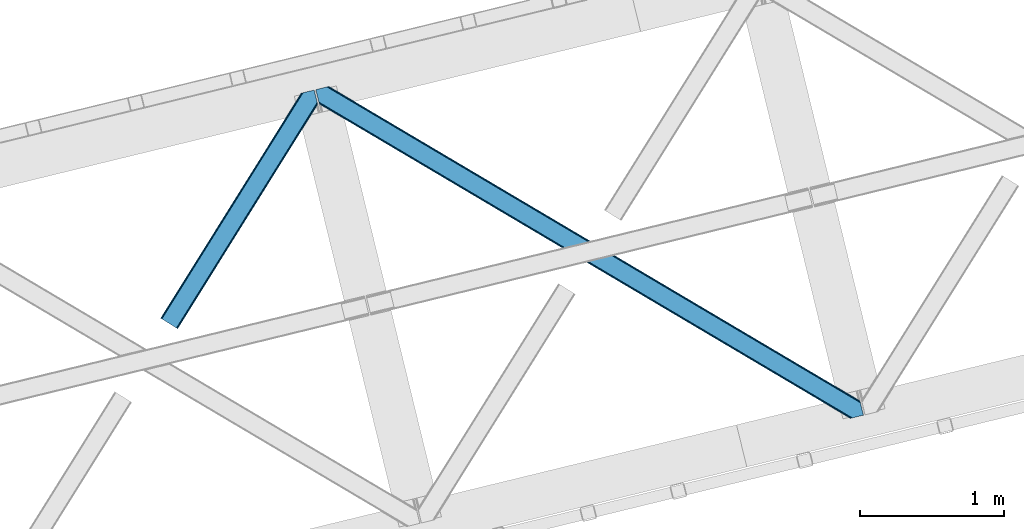
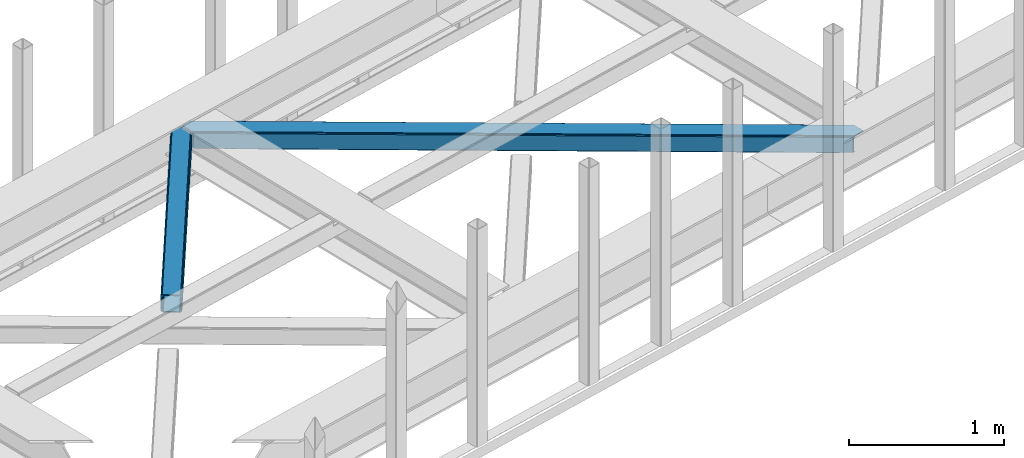
# One storey, part 43 of 66: 2 members.
"""IFC4 building model written with IfcOpenShell, lengths in millimetres."""

from ifc_helpers import new_model, entity, si_unit, converted_unit, derived_unit, direction, frame, origin, place, context, subcontext, project, spatial, triangles, type_object, element, save


model = new_model("IFC4")

# Units and contexts
model_context = context("Model", 3, precision=0.01, world=origin(), true_north=direction((6.12303176911189e-17, 1.0)))
plan_context = context("Plan", 3, precision=0.01, world=origin(), true_north=direction((6.12303176911189e-17, 1.0)))
body_context = subcontext(model_context, "Body", "Model", "MODEL_VIEW")
ifc_project = project(units=[si_unit("LENGTHUNIT", "METRE", prefix="MILLI"), si_unit("AREAUNIT", "SQUARE_METRE"), si_unit("VOLUMEUNIT", "CUBIC_METRE"), converted_unit("PLANEANGLEUNIT", "DEGREE", entity("IfcRatioMeasure", 0.0174532925199433), si_unit("PLANEANGLEUNIT", "RADIAN"), dimensions=[0, 0, 0, 0, 0, 0, 0]), si_unit("MASSUNIT", "GRAM", prefix="KILO"), derived_unit("MASSDENSITYUNIT", [(si_unit("MASSUNIT", "GRAM", prefix="KILO"), 1), (si_unit("LENGTHUNIT", "METRE"), -3)]), derived_unit("MOMENTOFINERTIAUNIT", [(si_unit("LENGTHUNIT", "METRE"), 4)]), si_unit("TIMEUNIT", "SECOND"), si_unit("FREQUENCYUNIT", "HERTZ"), si_unit("THERMODYNAMICTEMPERATUREUNIT", "DEGREE_CELSIUS"), derived_unit("THERMALTRANSMITTANCEUNIT", [(si_unit("MASSUNIT", "GRAM", prefix="KILO"), 1), (si_unit("THERMODYNAMICTEMPERATUREUNIT", "KELVIN"), -1), (si_unit("TIMEUNIT", "SECOND"), -3)]), derived_unit("VOLUMETRICFLOWRATEUNIT", [(si_unit("LENGTHUNIT", "METRE"), 3), (si_unit("TIMEUNIT", "SECOND"), -1)]), derived_unit("MASSFLOWRATEUNIT", [(si_unit("MASSUNIT", "GRAM", prefix="KILO"), 1), (si_unit("TIMEUNIT", "SECOND"), -1)]), derived_unit("ROTATIONALFREQUENCYUNIT", [(si_unit("TIMEUNIT", "SECOND"), -1)]), si_unit("ELECTRICCURRENTUNIT", "AMPERE"), si_unit("ELECTRICVOLTAGEUNIT", "VOLT"), si_unit("POWERUNIT", "WATT"), si_unit("FORCEUNIT", "NEWTON", prefix="KILO"), si_unit("ILLUMINANCEUNIT", "LUX"), si_unit("LUMINOUSFLUXUNIT", "LUMEN"), si_unit("LUMINOUSINTENSITYUNIT", "CANDELA"), derived_unit("USERDEFINED", [(si_unit("MASSUNIT", "GRAM", prefix="KILO"), -1), (si_unit("LENGTHUNIT", "METRE"), -2), (si_unit("TIMEUNIT", "SECOND"), 3), (si_unit("LUMINOUSFLUXUNIT", "LUMEN"), 1)]), derived_unit("LINEARVELOCITYUNIT", [(si_unit("LENGTHUNIT", "METRE"), 1), (si_unit("TIMEUNIT", "SECOND"), -1)]), si_unit("PRESSUREUNIT", "PASCAL"), derived_unit("USERDEFINED", [(si_unit("LENGTHUNIT", "METRE"), -2), (si_unit("MASSUNIT", "GRAM", prefix="KILO"), 1), (si_unit("TIMEUNIT", "SECOND"), -2)]), derived_unit("LINEARFORCEUNIT", [(si_unit("MASSUNIT", "GRAM", prefix="KILO"), 1), (si_unit("LENGTHUNIT", "METRE"), 1), (si_unit("TIMEUNIT", "SECOND"), -2), (si_unit("LENGTHUNIT", "METRE"), -1)]), derived_unit("PLANARFORCEUNIT", [(si_unit("MASSUNIT", "GRAM", prefix="KILO"), 1), (si_unit("LENGTHUNIT", "METRE"), 1), (si_unit("TIMEUNIT", "SECOND"), -2), (si_unit("LENGTHUNIT", "METRE"), -2)])], contexts=[model_context, plan_context])

# Site, building, storey
site_placement = place(None, origin())
site = spatial("IfcSite", under=ifc_project, at=site_placement, CompositionType="ELEMENT")
building_placement = place(site_placement, origin())
building = spatial("IfcBuilding", under=site, at=building_placement, CompositionType="ELEMENT")
storey_placement = place(building_placement, frame((0.0, 0.0, 19800.0)))
storey = spatial("IfcBuildingStorey", under=building, at=storey_placement, Name="06", CompositionType="ELEMENT", Elevation=19800.0)

# Members
member_type_1 = type_object("IfcMemberType", PredefinedType="BRACE")
member_1_placement = place(storey_placement, frame((-25090.06, 13275.86, 3823.0)))
element("IfcMember", 1, at=member_1_placement, inside=storey, type_object=member_type_1, ObjectType="Steel Horizontal Brace", PredefinedType="BRACE", context=body_context, shape_type="Tessellation", body=[
    triangles([(933.019793701173, 1535.69230957031, 0.0), (967.780462646486, 1393.09171142578, 0.0), (14.8456054687485, 64.8704589843746, 0.0), (103.916912841796, 9.2680389404286, 0.0), (928.803771972656, 1552.99125366211, 5.49966430664063), (928.943298339844, 1552.41687011719, 5.208984375), (930.803649902344, 1544.78710327148, 1.33247680664135), (971.996484374999, 1375.79276733398, 5.49966430664063), (971.856958007811, 1376.36715087891, 5.208984375), (969.996606445311, 1383.99691772461, 1.33247680664135), (972.210424804689, 1375.53813171387, 5.8531311035149), (972.422039794921, 1375.28349609375, 6.20659790039281), (928.913067626952, 1553.56912536621, 5.74383544921875), (972.724346923827, 1375.53813171387, 6.35310058593677), (929.029339599609, 1554.1772277832, 5.9996337890625), (973.026654052734, 1375.79276733398, 6.49960327148438), (929.143286132814, 1554.78416748047, 6.25543212890625), (929.254907226561, 1555.36203918457, 6.49960327148438), (4.34857177734375, 71.4223846435543, 5.12526855468968), (1.13248901367115, 73.4315643310547, 10.8039916992202), (973.359191894531, 1630.84347839355, 10.8039916992202), (976.914788818358, 1631.70970458984, 6.49960327148438), (9.16455688476708, 68.415591430663, 1.33247680664135), (971.508142089842, 1630.39118041992, 17.5012573242202), (0.0, 74.1361724853505, 17.5012573242202), (1081.10145263672, 1548.91708374023, 6.49960327148438), (1056.20762329101, 1651.03759460449, 6.49960327148438), (971.508142089842, 1630.39118041992, 122.499499511719), (0.0, 74.1361724853505, 122.499499511719), (973.359191894531, 1630.84347839355, 129.196765136719), (1.13248901367115, 73.4315643310547, 129.196765136719), (978.633288574219, 1632.12828369141, 134.87548828125), (4.34857177734375, 71.4223846435543, 134.87548828125), (986.525830078124, 1634.05258483887, 138.668280029298), (9.16455688476708, 68.415591430663, 138.668280029298), (995.83921508789, 1636.32221374512, 140.00075683594), (14.8456054687485, 64.8704589843746, 140.00075683594), (118.760192871094, 0.0, 17.5012573242202), (117.630029296874, 0.705770874023074, 10.8039916992202), (1085.14306640625, 1551.25066223144, 10.9783996582046), (1087.41734619141, 1552.56453552246, 13.4991760253906), (109.595635986327, 5.7205810546875, 1.33247680664135), (114.41162109375, 2.71495056152344, 5.12526855468968), (1087.56849975586, 1551.93550415039, 17.5012573242202), (1081.77583007812, 1575.70149536133, 140.00075683594), (1063.00720825195, 1652.69563293457, 140.00075683594), (103.916912841796, 9.2680389404286, 140.00075683594), (1083.99429931641, 1566.60670166016, 138.668280029298), (109.595635986327, 5.7205810546875, 138.668280029298), (1085.87325439453, 1558.89670715332, 134.87548828125), (114.41162109375, 2.71495056152344, 134.87548828125), (1087.12899169922, 1553.74469604492, 129.196765136719), (117.630029296874, 0.705770874023074, 129.196765136719), (1087.56849975586, 1551.93550415039, 122.499499511719), (118.760192871094, 0.0, 122.499499511719), (1082.53857421875, 1566.77297058105, 12.1248413085959), (1083.96406860352, 1566.72413635254, 13.4991760253906), (1077.85048828125, 1569.98556518555, 8.3320495605476), (1074.6483581543, 1577.50138549805, 6.99957275390625), (1056.69364013672, 1651.1561920166, 6.99957275390625), (1005.57350463867, 1638.69532470703, 6.99957275390625), (20.784777832032, 61.1625457763657, 6.99957275390625), (97.9754150390618, 12.9736267089829, 6.99957275390625), (108.47244873047, 6.42053833007776, 12.1248413085959), (111.690856933594, 4.41252136230469, 17.8035644531265), (1084.81052856445, 1563.2510925293, 17.8035644531265), (103.656463623047, 9.42733154296729, 8.3320495605476), (1085.25236206055, 1561.44190063477, 24.5008300781265), (112.823345947265, 3.70675048827979, 24.5008300781265), (983.093481445314, 1633.21542663574, 17.8035644531265), (981.24010620117, 1632.76429138184, 24.5008300781265), (7.0693359375, 69.7248138427731, 17.8035644531265), (5.93917236327979, 70.4305847167961, 24.5008300781265), (988.365252685548, 1634.50139465332, 12.1248413085959), (10.2877441406235, 67.7156341552727, 12.1248413085959), (996.262445068358, 1636.42569580078, 8.3320495605476), (15.1037292480469, 64.7100036621086, 8.3320495605476), (981.24010620117, 1632.76429138184, 115.499926757813), (5.93917236327979, 70.4305847167961, 115.499926757813), (996.262445068358, 1636.42569580078, 131.668707275392), (1005.57350463867, 1638.69532470703, 133.001184082033), (1063.00720825195, 1652.69563293457, 133.001184082033), (988.365252685548, 1634.50139465332, 127.873590087893), (983.093481445314, 1633.21542663574, 122.197192382813), (20.784777832032, 61.1625457763657, 133.001184082033), (15.1037292480469, 64.7100036621086, 131.668707275392), (10.2877441406235, 67.7156341552727, 127.873590087893), (7.0693359375, 69.7248138427731, 122.197192382813), (108.47244873047, 6.42053833007776, 127.873590087893), (111.690856933594, 4.41252136230469, 122.197192382813), (112.823345947265, 3.70675048827979, 115.499926757813), (97.9754150390618, 12.9736267089829, 133.001184082033), (103.656463623047, 9.42733154296729, 131.668707275392), (1085.25236206055, 1561.44190063477, 115.499926757813), (1084.81052856445, 1563.2510925293, 122.197192382813), (1083.55479125976, 1568.40310363769, 127.873590087893), (1081.67583618164, 1576.11309814453, 131.668707275392), (1079.45969238281, 1585.20905456543, 133.001184082033)], [[1, 2, 3], [4, 3, 2], [1, 5, 2], [6, 5, 1], [1, 7, 6], [2, 5, 8], [8, 9, 2], [10, 2, 9], [11, 8, 5], [12, 11, 13], [14, 12, 15], [16, 14, 17], [17, 18, 16], [15, 17, 14], [13, 15, 12], [5, 13, 11], [17, 19, 18], [19, 17, 15], [13, 19, 15], [19, 13, 5], [5, 6, 19], [20, 21, 18], [18, 19, 20], [21, 22, 18], [19, 6, 7], [7, 1, 23], [3, 23, 1], [7, 23, 19], [24, 21, 20], [20, 25, 24], [18, 26, 16], [26, 18, 22], [27, 26, 22], [28, 24, 25], [25, 29, 28], [30, 28, 31], [29, 31, 28], [32, 30, 33], [31, 33, 30], [34, 32, 35], [33, 35, 32], [36, 34, 37], [35, 37, 34], [38, 39, 40], [40, 41, 38], [42, 10, 9], [39, 12, 16], [16, 40, 39], [16, 26, 40], [9, 39, 43], [9, 12, 39], [9, 43, 42], [2, 10, 4], [42, 4, 10], [41, 44, 38], [45, 36, 37], [36, 45, 46], [37, 47, 45], [48, 45, 47], [47, 49, 48], [50, 48, 49], [49, 51, 50], [52, 50, 51], [51, 53, 52], [54, 52, 53], [53, 55, 54], [44, 54, 38], [55, 38, 54], [56, 40, 26], [41, 40, 56], [56, 57, 41], [58, 26, 59], [26, 58, 56], [60, 59, 26], [59, 61, 62], [61, 59, 60], [62, 63, 59], [64, 65, 66], [66, 57, 64], [58, 59, 63], [63, 67, 58], [56, 58, 67], [67, 64, 56], [57, 56, 64], [68, 66, 65], [65, 69, 68], [70, 71, 72], [73, 72, 71], [74, 70, 75], [72, 75, 70], [76, 74, 77], [75, 77, 74], [61, 76, 62], [77, 62, 76], [71, 78, 73], [79, 73, 78], [34, 36, 80], [46, 81, 36], [81, 46, 82], [81, 80, 36], [83, 34, 80], [83, 32, 34], [32, 84, 30], [84, 32, 83], [28, 84, 78], [84, 28, 30], [61, 22, 76], [70, 74, 22], [74, 76, 22], [61, 60, 22], [71, 70, 24], [21, 24, 70], [28, 71, 24], [71, 28, 78], [70, 22, 21], [80, 81, 85], [85, 86, 80], [83, 80, 86], [86, 87, 83], [84, 83, 87], [87, 88, 84], [78, 84, 88], [88, 79, 78], [53, 89, 90], [91, 38, 55], [53, 90, 55], [53, 51, 89], [90, 91, 55], [89, 51, 49], [92, 47, 37], [47, 93, 49], [93, 47, 92], [93, 89, 49], [39, 64, 43], [69, 38, 91], [38, 65, 39], [65, 38, 69], [39, 65, 64], [4, 63, 3], [42, 43, 64], [64, 67, 42], [67, 63, 4], [4, 42, 67], [87, 35, 33], [37, 85, 92], [37, 86, 85], [86, 37, 35], [87, 86, 35], [79, 29, 25], [31, 88, 87], [33, 31, 87], [88, 31, 29], [79, 88, 29], [23, 75, 19], [3, 63, 62], [62, 77, 3], [77, 75, 23], [23, 3, 77], [20, 19, 75], [25, 73, 79], [72, 25, 20], [25, 72, 73], [72, 20, 75], [66, 41, 57], [54, 44, 68], [44, 66, 68], [68, 94, 54], [44, 41, 66], [95, 54, 94], [52, 54, 95], [50, 95, 96], [95, 50, 52], [96, 48, 50], [97, 48, 96], [97, 98, 45], [97, 45, 48], [98, 46, 45], [98, 82, 46], [81, 98, 85], [81, 82, 98], [92, 85, 98], [95, 94, 90], [91, 90, 94], [96, 95, 89], [90, 89, 95], [97, 96, 93], [89, 93, 96], [98, 97, 92], [93, 92, 97], [94, 68, 69], [69, 91, 94]]),
])
member_type_2 = type_object("IfcMemberType", PredefinedType="BRACE")
member_2_placement = place(storey_placement, frame((-24015.39, 12655.92, 3823.0)))
element("IfcMember", 2, at=member_2_placement, inside=storey, type_object=member_type_2, ObjectType="Steel Horizontal Brace", PredefinedType="BRACE", context=body_context, shape_type="Tessellation", body=[
    triangles([(3167.12528686523, 476.930191040039, 17.5012573242202), (3764.84926757812, 123.064581298828, 122.499499511719), (3764.84926757812, 123.064581298828, 17.5012573242202), (2547.33288574219, 843.861282348633, 17.5012573242202), (1927.54048461914, 1210.79353637695, 17.5012573242202), (91.5013916015632, 2297.7748626709, 122.499499511719), (687.9580078125, 1944.65804443359, 17.5012573242202), (91.5013916015632, 2297.7748626709, 17.5012573242202), (1307.7480834961, 1577.72579040527, 17.5012573242202), (3770.64193725586, 99.297427368163, 140.00075683594), (3768.42346801758, 108.393383789062, 138.668280029298), (76.4813781738267, 2294.11345825195, 138.668280029298), (67.167993164061, 2291.8438293457, 140.00075683594), (3766.54451293945, 116.103378295898, 134.87548828125), (84.3739196777351, 2296.03775939941, 134.87548828125), (3765.28877563477, 121.255389404296, 129.196765136719), (89.6503417968743, 2297.32372741699, 129.196765136719), (3722.24024047852, 5.93103332519422, 140.00075683594), (18.7662963867188, 2198.47743530273, 140.00075683594), (3789.41055908203, 22.304452514647, 140.00075683594), (0.0, 2275.47041015625, 140.00075683594), (3697.90916748047, 0.0, 122.499499511719), (3699.76021728515, 0.451135253904795, 129.196765136719), (24.1194580078118, 2176.5194732666, 129.196765136719), (24.5612915039055, 2174.71028137207, 122.499499511719), (3705.03431396484, 1.73710327148365, 134.87548828125), (22.8637207031243, 2181.671484375, 134.87548828125), (3712.9291809082, 3.66024169921729, 138.668280029298), (20.9847656249985, 2189.38147888184, 138.668280029298), (1862.08401489258, 1086.85342712402, 17.5012573242202), (2481.93687744141, 719.881640624999, 17.5012573242202), (3101.79671630859, 352.912179565428, 17.5012573242202), (3697.90916748047, 0.0, 17.5012573242202), (1242.22417602539, 1453.82288818359, 17.5012573242202), (622.368988037109, 1820.79467468262, 17.5012573242202), (24.5612915039055, 2174.71028137207, 17.5012573242202), (74.641955566407, 2293.66581115723, 127.873590087893), (66.7470886230476, 2291.74151000977, 131.668707275392), (79.9160522460952, 2294.9517791748, 122.197192382813), (57.433703613282, 2289.47071838379, 133.001184082033), (0.0, 2275.47041015625, 133.001184082033), (81.7671020507805, 2295.40175170898, 115.499926757813), (81.7671020507805, 2295.40175170898, 24.5008300781265), (79.9160522460952, 2294.9517791748, 17.8035644531265), (89.5619750976548, 2297.30279846191, 10.8156188964858), (89.4689575195298, 2297.27954406738, 10.4993591308594), (74.1140808105483, 2293.53674926758, 12.4271484375022), (72.0351379394524, 2293.0298034668, 10.4993591308594), (1922.1942993164, 1205.8275604248, 24.5008300781265), (3767.16540527344, 113.558184814452, 115.499926757813), (2545.10744018555, 837.044256591797, 24.5008300781265), (3168.02755737305, 468.263278198241, 24.5008300781265), (3767.16540527344, 113.558184814452, 24.5008300781265), (1299.27418212891, 1574.60853881836, 24.5008300781265), (676.358715820312, 1943.39067993164, 24.5008300781265), (3767.60723876953, 111.748992919922, 122.197192382813), (3768.86297607422, 106.596981811523, 127.873590087893), (3770.74193115234, 98.8858245849606, 131.668707275392), (3772.95807495117, 89.7910308837891, 133.001184082033), (3767.69560546875, 111.385061645507, 17.8686767578147), (3767.80257568359, 110.943228149414, 16.5199218750022), (3764.85624389648, 123.027374267578, 16.5199218750022), (3789.41055908203, 22.304452514647, 133.001184082033), (3731.9745300293, 8.30298156738172, 133.001184082033), (16.4501586914048, 2207.98383178711, 133.001184082033), (162.736578369142, 2253.90428466797, 10.4993591308594), (166.88748779297, 2236.87509155273, 10.4993591308594), (3722.66114501953, 6.03335266113208, 131.668707275392), (18.6663024902336, 2198.88787536621, 131.668707275392), (3714.76627807617, 4.10905151367115, 127.873590087893), (20.5452575683594, 2191.17788085938, 127.873590087893), (3709.49450683594, 2.82424621581958, 122.197192382813), (21.8033203125015, 2186.02586975098, 122.197192382813), (3707.6411315918, 2.3719482421875, 115.499926757813), (22.2428283691406, 2184.21667785644, 115.499926757813), (3114.18665771484, 353.712130737304, 24.5008300781265), (3707.6411315918, 2.3719482421875, 24.5008300781265), (2491.11771240235, 722.582638549804, 24.5008300781265), (1868.0510925293, 1091.4531463623, 24.5008300781265), (621.917852783205, 1829.19532470703, 24.5008300781265), (22.2428283691406, 2184.21667785644, 24.5008300781265), (1244.9867980957, 1460.32481689453, 24.5008300781265), (3709.49450683594, 2.82424621581958, 17.8035644531265), (3700.13228759765, 0.541827392577034, 10.8691040039084), (3700.58342285156, 0.651123046875, 9.52034912109593), (3714.76627807617, 4.10905151367115, 12.1248413085959), (3719.39390258789, 5.23688964843677, 9.52034912109593), (21.7823913574211, 2186.11074829102, 17.817517089843), (21.7591369628899, 2186.20144042969, 17.5012573242202), (32.1375732421875, 2171.84650268555, 10.8179443359368), (28.3471069335938, 2188.73849487305, 10.4993591308594), (27.0099792480469, 2187.35020751953, 12.1248413085959), (32.4980163574219, 2171.71046447754, 10.4993591308594), (203.964294433594, 2084.76809692383, 10.4993591308594), (208.115203857422, 2067.73890380859, 10.4993591308594), (164.09696044922, 2252.54739074707, 9.49942016601563), (168.582733154297, 2234.14386291504, 9.49942016601563), (168.164154052734, 2234.81707763672, 9.74591674804833), (163.769073486328, 2252.87527770996, 9.74126586914281), (167.733947753906, 2235.50889587402, 9.9993896484375), (163.415606689454, 2253.22525634766, 9.9993896484375), (167.306066894533, 2236.20187683105, 10.2528625488303), (163.064465332031, 2253.57639770508, 10.2598388671868), (209.161651611328, 2067.67146606445, 9.49942016601563), (209.136071777342, 2067.46682739258, 9.88311767578125), (204.678204345702, 2085.44247436523, 9.8528869628899), (208.801208496094, 2067.5551940918, 10.0831054687515), (204.682855224608, 2084.81111755371, 10.2063537597678), (208.447741699219, 2067.65053710938, 10.2993713378928), (204.322412109374, 2084.78902587891, 10.3528564453118), (204.675878906251, 2086.07383117676, 9.49942016601563), (3763.57492675781, 109.725860595703, 12.1248413085959), (3758.56825561524, 124.970278930663, 10.8714294433594), (3757.06602172851, 125.435366821288, 9.52034912109593), (3761.54481811524, 107.063232421875, 9.52034912109593), (3585.92530517578, 211.033630371094, 9.52034912109593), (3581.44650878906, 229.405764770507, 9.52034912109593), (3585.50672607422, 211.133624267577, 9.44360961914208), (3581.04653320312, 229.55343017578, 9.37384643554833), (3580.64655761719, 229.699932861327, 9.22734375000073), (3580.53493652344, 229.532501220703, 8.87387695312646), (3585.4578918457, 210.476687622069, 9.13897705078125), (3580.42796630859, 229.365069580077, 8.52041015625218), (3585.40673217773, 209.805798339843, 8.82736816406396), (3585.35557250976, 209.147698974608, 8.52041015625218), (3164.51381835937, 472.51883239746, 5.12526855468968), (3581.30233154297, 225.771102905273, 5.12526855468968), (3166.44858398438, 475.783749389648, 10.8039916992202), (687.281304931639, 1943.5116027832, 10.8039916992202), (685.34653930664, 1940.24784851074, 5.12526855468968), (165.152709960938, 2248.2150970459, 5.12526855468968), (682.456018066405, 1935.36210021973, 1.33247680664135), (167.031665039063, 2240.50393981933, 1.33247680664135), (679.044598388671, 1929.59966125488, 0.0), (169.247808837892, 2231.40914611816, 0.0), (3583.18361206055, 218.061108398437, 1.33247680664135), (3585.39975585938, 208.965151977538, 0.0), (3158.2118774414, 461.8706451416, 0.0), (3161.62329711914, 467.633084106445, 1.33247680664135), (2546.65618286133, 842.716003417969, 10.8039916992202), (1926.86378173828, 1209.64709472656, 10.8039916992202), (1307.07138061523, 1576.57934875488, 10.8039916992202), (2544.72141723633, 839.451086425781, 5.12526855468968), (1924.92901611328, 1206.3833404541, 5.12526855468968), (1305.13661499024, 1573.31443176269, 5.12526855468968), (2541.83089599609, 834.565338134766, 1.33247680664135), (1922.03849487305, 1201.49759216308, 1.33247680664135), (1302.24609375, 1568.42984619141, 1.33247680664135), (2538.41947631836, 828.802899169921, 0.0), (1918.62707519531, 1195.73515319824, 0.0), (1298.83467407227, 1562.66740722656, 0.0), (3620.16042480469, 66.3657165527329, 0.0), (3110.71245117188, 367.97056274414, 0.0), (2490.85726318359, 734.941186523436, 0.0), (1870.99742431641, 1101.91181030273, 0.0), (631.284722900389, 1835.85305786133, 0.0), (1251.13758544922, 1468.8812713623, 0.0), (204.008477783202, 2088.80854797363, 0.0), (3167.34852905274, 467.116836547852, 17.8035644531265), (3165.41608886719, 463.853082275389, 12.1248413085959), (673.749572753906, 1938.98048400879, 12.1248413085959), (675.682012939455, 1942.24423828125, 17.8035644531265), (670.85672607422, 1934.09473571777, 8.3320495605476), (169.396636962891, 2230.80104370117, 8.81806640624927), (171.566271972657, 2221.90274963379, 6.99957275390625), (3159.11182250977, 453.204895019531, 6.99957275390625), (3587.71821899414, 199.458755493164, 6.99957275390625), (3585.50672607422, 208.524481201172, 8.42274169921802), (3162.5232421875, 458.967333984374, 8.3320495605476), (667.442980957032, 1928.3311340332, 6.99957275390625), (2536.19403076172, 821.985873413085, 6.99957275390625), (2539.60545043945, 827.748312377929, 8.3320495605476), (1913.27856445313, 1190.76801452637, 6.99957275390625), (1916.68998413086, 1196.53045349121, 8.3320495605476), (1290.36077270508, 1559.54899291992, 6.99957275390625), (1293.76986694336, 1565.31259460449, 8.3320495605476), (2542.49597167969, 832.634060668945, 12.1248413085959), (1919.58283081055, 1201.41620178223, 12.1248413085959), (1296.66271362305, 1570.19718017578, 12.1248413085959), (2544.43073730469, 835.898977661132, 17.8035644531265), (1921.51527099609, 1204.68111877441, 17.8035644531265), (1298.59515380859, 1573.46209716797, 17.8035644531265), (201.692340087891, 2098.31610717773, 6.99957275390625), (203.861975097658, 2089.41665039063, 8.81806640624927), (206.226947021485, 2079.71375427246, 1.33247680664135), (208.105902099611, 2072.00375976562, 5.12526855468968), (2500.03577270508, 737.642184448241, 6.99957275390625), (3123.10239257813, 368.771676635741, 6.99957275390625), (1876.96682739258, 1106.51269226074, 6.99957275390625), (3617.84196166992, 75.8721130371086, 6.99957275390625), (630.833587646484, 1844.25370788574, 6.99957275390625), (1253.90020751953, 1475.38320007324, 6.99957275390625), (3119.69097290039, 363.009237670898, 8.3320495605476), (3620.56040039063, 65.0390533447262, 8.90410766601781), (3620.2046081543, 66.183169555663, 8.52041015625218), (3116.7981262207, 358.123489379883, 12.1248413085959), (3621.05106811523, 64.3204925537102, 9.1087463378899), (3621.5487121582, 63.5914672851559, 9.31571044922021), (3622.04170532227, 62.8729064941399, 9.52034912109593), (3620.05345458984, 66.8063873291012, 8.42274169921802), (624.529321289061, 1833.60552062988, 12.1248413085959), (627.422167968751, 1838.4912689209, 8.3320495605476), (622.596881103516, 1830.34176635742, 17.8035644531265), (3114.86568603515, 354.858572387695, 17.8035644531265), (2491.79906616211, 723.730242919921, 17.8035644531265), (1868.73012084961, 1092.59958801269, 17.8035644531265), (1245.66350097656, 1461.47125854492, 17.8035644531265), (2493.72685546875, 726.992834472656, 12.1248413085959), (1870.66256103515, 1095.86450500488, 12.1248413085959), (1247.59594116211, 1464.73501281738, 12.1248413085959), (2496.61970214844, 731.878582763671, 8.3320495605476), (1873.55540771484, 1100.74909057617, 8.3320495605476), (1250.4887878418, 1469.6207611084, 8.3320495605476), (3102.47574462891, 354.057458496092, 10.8039916992202), (624.980456542969, 1825.20487060547, 5.12526855468968), (623.048016357421, 1821.93995361328, 10.8039916992202), (3626.51817626953, 44.5007720947251, 9.52034912109593), (3104.40818481445, 357.32237548828, 5.12526855468968), (3624.25552368164, 49.5597656249993, 5.12526855468968), (3625.13221435547, 45.9657989501939, 8.52041015625218), (3625.82286987305, 45.2332855224595, 9.02037963867406), (3622.37656860351, 57.2697601318359, 1.33247680664135), (3107.30103149414, 362.208123779295, 1.33247680664135), (627.873303222656, 1830.09061889648, 1.33247680664135), (2487.44119262695, 729.177584838866, 1.33247680664135), (1867.58600463867, 1096.14937133789, 1.33247680664135), (1247.72849121094, 1463.11883239746, 1.33247680664135), (2484.55299682617, 724.292999267578, 5.12526855468968), (1864.69315795898, 1091.26362304687, 5.12526855468968), (1244.83564453125, 1458.23308410644, 5.12526855468968), (2482.62055664062, 721.029244995116, 10.8039916992202), (1862.76071777344, 1087.99870605469, 10.8039916992202), (1242.9032043457, 1454.96932983398, 10.8039916992202)], [[1, 2, 3], [2, 1, 4], [2, 5, 6], [5, 2, 4], [7, 8, 6], [9, 6, 5], [6, 9, 7], [10, 11, 12], [12, 13, 10], [11, 14, 15], [15, 12, 11], [14, 16, 17], [17, 15, 14], [16, 2, 6], [6, 17, 16], [18, 10, 19], [18, 20, 10], [13, 19, 10], [21, 19, 13], [22, 23, 24], [24, 25, 22], [23, 26, 27], [27, 24, 23], [26, 28, 29], [29, 27, 26], [28, 18, 19], [19, 29, 28], [30, 22, 25], [22, 31, 32], [30, 31, 22], [32, 33, 22], [34, 25, 35], [25, 34, 30], [36, 35, 25], [37, 38, 12], [15, 37, 12], [15, 17, 39], [37, 15, 39], [39, 17, 6], [38, 13, 12], [21, 40, 41], [21, 13, 40], [38, 40, 13], [39, 6, 42], [43, 8, 44], [6, 43, 42], [8, 45, 44], [6, 8, 43], [46, 44, 45], [46, 47, 44], [46, 48, 47], [49, 50, 42], [50, 51, 52], [49, 51, 50], [52, 53, 50], [54, 42, 55], [42, 54, 49], [43, 55, 42], [50, 56, 42], [39, 42, 56], [56, 57, 39], [37, 39, 57], [57, 58, 37], [38, 37, 58], [58, 59, 38], [40, 38, 59], [57, 14, 11], [59, 58, 10], [58, 57, 11], [60, 61, 62], [63, 59, 20], [10, 20, 59], [58, 11, 10], [60, 3, 53], [2, 50, 53], [53, 3, 2], [60, 62, 3], [2, 56, 50], [56, 14, 57], [14, 56, 16], [2, 16, 56], [59, 64, 65], [64, 59, 63], [65, 40, 59], [41, 40, 65], [66, 67, 46], [48, 46, 67], [64, 68, 65], [69, 65, 68], [68, 70, 69], [71, 69, 70], [70, 72, 71], [73, 71, 72], [72, 74, 73], [75, 73, 74], [76, 74, 77], [74, 76, 78], [74, 79, 75], [79, 74, 78], [80, 81, 75], [82, 75, 79], [75, 82, 80], [70, 68, 28], [26, 70, 28], [26, 23, 72], [70, 26, 72], [72, 23, 22], [68, 18, 28], [20, 64, 63], [20, 18, 64], [68, 64, 18], [72, 22, 74], [77, 33, 83], [22, 77, 74], [33, 84, 83], [22, 33, 77], [85, 83, 84], [86, 83, 85], [87, 86, 85], [73, 75, 25], [25, 24, 73], [27, 73, 24], [73, 27, 71], [25, 81, 36], [88, 89, 36], [36, 81, 88], [75, 81, 25], [69, 29, 19], [21, 65, 19], [41, 65, 21], [69, 71, 29], [29, 71, 27], [65, 69, 19], [90, 91, 92], [90, 93, 91], [92, 36, 90], [89, 36, 92], [94, 95, 93], [93, 91, 94], [96, 97, 98], [98, 99, 96], [99, 98, 100], [100, 101, 99], [101, 100, 102], [102, 103, 101], [103, 102, 67], [67, 66, 103], [104, 105, 106], [105, 107, 108], [108, 107, 109], [110, 109, 95], [95, 94, 110], [109, 110, 108], [108, 106, 105], [106, 111, 104], [62, 112, 113], [112, 62, 61], [112, 114, 113], [112, 115, 114], [114, 115, 116], [116, 117, 114], [118, 119, 117], [120, 119, 118], [121, 120, 122], [123, 121, 124], [124, 125, 123], [122, 124, 121], [118, 122, 120], [117, 116, 118], [1, 3, 113], [3, 62, 113], [120, 121, 126], [123, 126, 121], [123, 127, 126], [128, 113, 117], [117, 126, 128], [117, 119, 126], [120, 126, 119], [113, 114, 117], [45, 129, 66], [129, 130, 131], [131, 96, 129], [129, 99, 101], [99, 129, 96], [129, 103, 66], [103, 129, 101], [129, 45, 8], [8, 7, 129], [66, 46, 45], [130, 132, 133], [133, 131, 130], [132, 134, 135], [135, 133, 132], [136, 137, 138], [138, 139, 136], [127, 136, 139], [139, 126, 127], [113, 128, 1], [1, 128, 140], [140, 4, 1], [4, 140, 5], [141, 5, 140], [5, 141, 142], [142, 9, 5], [9, 142, 129], [129, 7, 9], [128, 126, 140], [143, 140, 126], [140, 143, 141], [144, 141, 143], [141, 144, 145], [145, 142, 141], [142, 145, 130], [130, 129, 142], [126, 139, 146], [146, 143, 126], [143, 146, 147], [147, 144, 143], [144, 147, 145], [148, 145, 147], [145, 148, 130], [132, 130, 148], [139, 138, 146], [149, 146, 138], [146, 149, 147], [150, 147, 149], [147, 150, 148], [151, 148, 150], [148, 151, 134], [134, 132, 148], [137, 152, 153], [138, 153, 154], [153, 138, 137], [149, 155, 150], [154, 149, 138], [149, 154, 155], [156, 134, 151], [150, 157, 151], [157, 150, 155], [157, 156, 151], [158, 134, 156], [135, 134, 158], [159, 160, 112], [112, 61, 159], [159, 60, 53], [161, 162, 44], [98, 163, 100], [98, 97, 163], [163, 102, 100], [163, 67, 102], [97, 164, 163], [161, 47, 67], [67, 163, 161], [47, 48, 67], [163, 164, 165], [166, 167, 168], [160, 118, 116], [116, 112, 160], [116, 115, 112], [169, 168, 125], [125, 160, 169], [124, 122, 160], [122, 118, 160], [160, 125, 124], [168, 169, 166], [165, 170, 163], [44, 47, 161], [162, 55, 43], [43, 44, 162], [53, 52, 159], [61, 60, 159], [166, 169, 171], [172, 171, 169], [171, 172, 173], [174, 173, 172], [173, 174, 175], [176, 175, 174], [175, 176, 163], [163, 170, 175], [169, 160, 177], [177, 172, 169], [172, 177, 178], [178, 174, 172], [174, 178, 179], [179, 176, 174], [176, 179, 163], [161, 163, 179], [160, 159, 177], [180, 177, 159], [177, 180, 178], [181, 178, 180], [178, 181, 179], [182, 179, 181], [179, 182, 162], [162, 161, 179], [159, 52, 180], [51, 180, 52], [180, 51, 49], [49, 181, 180], [181, 49, 182], [54, 182, 49], [182, 54, 162], [55, 162, 54], [97, 131, 133], [135, 97, 133], [165, 164, 135], [165, 135, 183], [131, 97, 96], [135, 164, 97], [183, 158, 184], [158, 185, 111], [158, 183, 135], [186, 111, 185], [158, 111, 184], [186, 104, 111], [187, 188, 166], [166, 171, 187], [171, 189, 187], [189, 171, 173], [188, 167, 166], [188, 190, 167], [170, 191, 175], [191, 170, 183], [165, 183, 170], [192, 175, 191], [173, 192, 189], [175, 192, 173], [193, 194, 195], [196, 197, 194], [196, 198, 197], [196, 199, 198], [194, 193, 196], [195, 200, 193], [86, 87, 199], [199, 196, 86], [193, 200, 190], [191, 183, 184], [201, 108, 110], [110, 94, 201], [94, 92, 201], [94, 91, 92], [202, 106, 108], [202, 111, 106], [202, 184, 111], [108, 201, 202], [203, 201, 92], [92, 89, 203], [203, 88, 81], [81, 80, 203], [89, 88, 203], [184, 202, 191], [190, 188, 193], [83, 86, 196], [196, 204, 83], [77, 83, 204], [204, 76, 77], [76, 204, 205], [205, 78, 76], [78, 205, 206], [206, 79, 78], [79, 206, 82], [207, 82, 206], [82, 207, 80], [203, 80, 207], [204, 196, 205], [208, 205, 196], [205, 208, 209], [209, 206, 205], [206, 209, 210], [210, 207, 206], [207, 210, 201], [201, 203, 207], [196, 193, 211], [211, 208, 196], [208, 211, 212], [212, 209, 208], [209, 212, 210], [213, 210, 212], [210, 213, 201], [202, 201, 213], [193, 188, 211], [187, 211, 188], [211, 187, 189], [189, 212, 211], [212, 189, 213], [192, 213, 189], [213, 192, 191], [191, 202, 213], [214, 84, 33], [35, 36, 90], [215, 105, 104], [216, 90, 95], [95, 215, 216], [95, 107, 215], [104, 186, 215], [84, 214, 217], [214, 218, 219], [219, 220, 214], [221, 217, 214], [214, 220, 221], [217, 85, 84], [222, 219, 218], [218, 223, 222], [152, 222, 223], [223, 153, 152], [156, 224, 185], [185, 158, 156], [224, 215, 186], [186, 185, 224], [90, 216, 35], [33, 32, 214], [153, 223, 154], [225, 154, 223], [154, 225, 155], [226, 155, 225], [155, 226, 157], [227, 157, 226], [157, 227, 224], [224, 156, 157], [223, 218, 228], [228, 225, 223], [225, 228, 229], [229, 226, 225], [226, 229, 230], [230, 227, 226], [227, 230, 224], [215, 224, 230], [218, 214, 228], [231, 228, 214], [228, 231, 229], [232, 229, 231], [229, 232, 230], [233, 230, 232], [230, 233, 215], [216, 215, 233], [214, 32, 31], [31, 231, 214], [231, 31, 30], [30, 232, 231], [232, 30, 34], [34, 233, 232], [233, 34, 35], [35, 216, 233], [137, 167, 190], [125, 127, 123], [137, 125, 167], [125, 136, 127], [125, 137, 136], [152, 137, 190], [195, 152, 190], [219, 195, 220], [195, 222, 152], [195, 219, 222], [220, 195, 194], [221, 194, 197], [221, 197, 198], [217, 198, 199], [87, 85, 199], [217, 199, 85]]),
])

save(model, "model.ifc")
